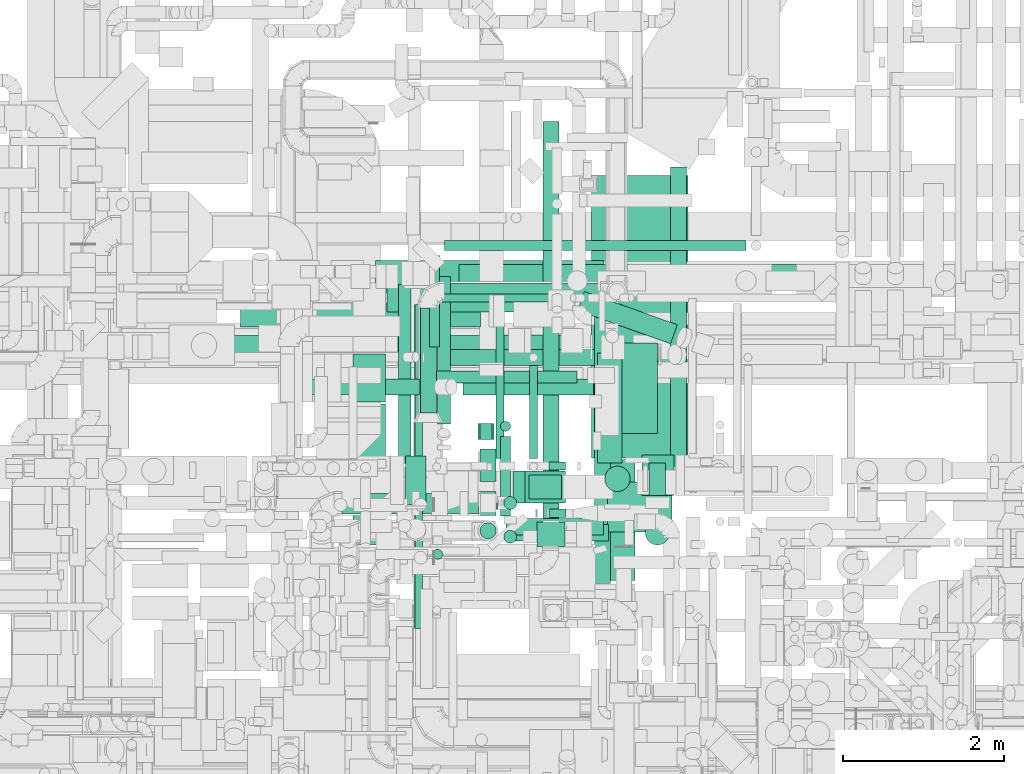
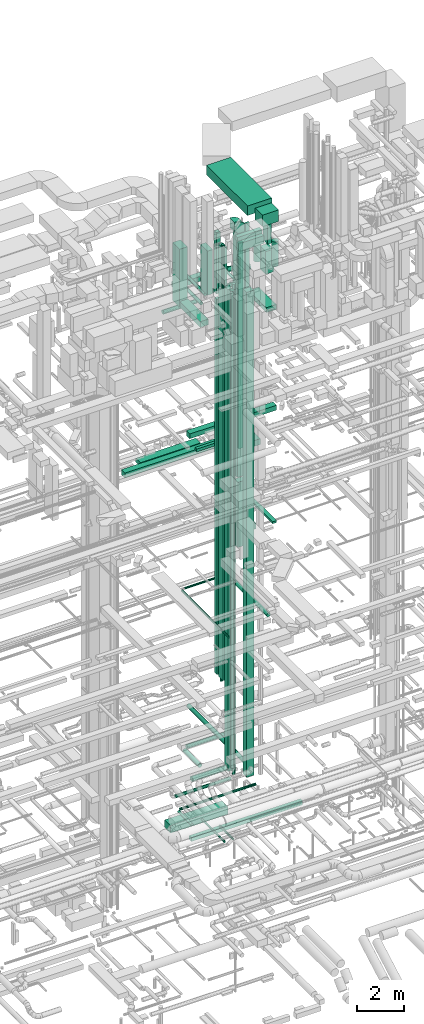
# One storey, part 48 of 337: 54 flow segments, 1 flow fitting.
"""IFC2X3 building model written with IfcOpenShell, lengths in millimetres."""

from ifc_helpers import new_model, entity, si_unit, converted_unit, derived_unit, direction, frame, frame_2d, origin, origin_2d_with_axis, place, context, subcontext, project, spatial, polyline, circle_curve, parameter, trimmed, segment, composite_curve, rectangle, circle, outline, extrude, source, transform, mapped, material, type_object, type_shapes, element, save


model = new_model("IFC2X3")

# Units and contexts
model_context = context("Model", 3, precision=0.01, world=origin(), true_north=direction((6.12303176911189e-17, 1.0)))
body_context = subcontext(model_context, "Body", "Model", "MODEL_VIEW")
ifc_project = project(units=[si_unit("LENGTHUNIT", "METRE", prefix="MILLI"), si_unit("AREAUNIT", "SQUARE_METRE"), si_unit("VOLUMEUNIT", "CUBIC_METRE"), converted_unit("PLANEANGLEUNIT", "DEGREE", entity("IfcRatioMeasure", 0.0174532925199433), si_unit("PLANEANGLEUNIT", "RADIAN"), dimensions=[0, 0, 0, 0, 0, 0, 0]), si_unit("MASSUNIT", "GRAM", prefix="KILO"), derived_unit("MASSDENSITYUNIT", [(si_unit("MASSUNIT", "GRAM", prefix="KILO"), 1), (si_unit("LENGTHUNIT", "METRE"), -3)]), derived_unit("MOMENTOFINERTIAUNIT", [(si_unit("LENGTHUNIT", "METRE"), 4)]), si_unit("TIMEUNIT", "SECOND"), si_unit("FREQUENCYUNIT", "HERTZ"), si_unit("THERMODYNAMICTEMPERATUREUNIT", "DEGREE_CELSIUS"), derived_unit("THERMALTRANSMITTANCEUNIT", [(si_unit("MASSUNIT", "GRAM", prefix="KILO"), 1), (si_unit("THERMODYNAMICTEMPERATUREUNIT", "KELVIN"), -1), (si_unit("TIMEUNIT", "SECOND"), -3)]), derived_unit("VOLUMETRICFLOWRATEUNIT", [(si_unit("LENGTHUNIT", "METRE"), 3), (si_unit("TIMEUNIT", "SECOND"), -1)]), derived_unit("MASSFLOWRATEUNIT", [(si_unit("MASSUNIT", "GRAM", prefix="KILO"), 1), (si_unit("TIMEUNIT", "SECOND"), -1)]), derived_unit("ROTATIONALFREQUENCYUNIT", [(si_unit("TIMEUNIT", "SECOND"), -1)]), si_unit("ELECTRICCURRENTUNIT", "AMPERE"), si_unit("ELECTRICVOLTAGEUNIT", "VOLT"), si_unit("POWERUNIT", "WATT"), si_unit("FORCEUNIT", "NEWTON", prefix="KILO"), si_unit("ILLUMINANCEUNIT", "LUX"), si_unit("LUMINOUSFLUXUNIT", "LUMEN"), si_unit("LUMINOUSINTENSITYUNIT", "CANDELA"), derived_unit("USERDEFINED", [(si_unit("MASSUNIT", "GRAM", prefix="KILO"), -1), (si_unit("LENGTHUNIT", "METRE"), -2), (si_unit("TIMEUNIT", "SECOND"), 3), (si_unit("LUMINOUSFLUXUNIT", "LUMEN"), 1)]), derived_unit("LINEARVELOCITYUNIT", [(si_unit("LENGTHUNIT", "METRE"), 1), (si_unit("TIMEUNIT", "SECOND"), -1)]), si_unit("PRESSUREUNIT", "PASCAL"), derived_unit("USERDEFINED", [(si_unit("LENGTHUNIT", "METRE"), -2), (si_unit("MASSUNIT", "GRAM", prefix="KILO"), 1), (si_unit("TIMEUNIT", "SECOND"), -2)]), derived_unit("LINEARFORCEUNIT", [(si_unit("MASSUNIT", "GRAM", prefix="KILO"), 1), (si_unit("LENGTHUNIT", "METRE"), 1), (si_unit("TIMEUNIT", "SECOND"), -2), (si_unit("LENGTHUNIT", "METRE"), -1)]), derived_unit("PLANARFORCEUNIT", [(si_unit("MASSUNIT", "GRAM", prefix="KILO"), 1), (si_unit("LENGTHUNIT", "METRE"), 1), (si_unit("TIMEUNIT", "SECOND"), -2), (si_unit("LENGTHUNIT", "METRE"), -2)])], contexts=[model_context])

# Site, building, storey
site_placement = place(None, origin())
site = spatial("IfcSite", under=ifc_project, at=site_placement, CompositionType="ELEMENT")
building_placement = place(site_placement, origin())
building = spatial("IfcBuilding", under=site, at=building_placement, CompositionType="ELEMENT")
storey_placement = place(building_placement, origin())
storey = spatial("IfcBuildingStorey", under=building, at=storey_placement, CompositionType="ELEMENT", Elevation=0.0)

# Flow segments
duct_segment_type_1 = type_object("IfcDuctSegmentType", PredefinedType="NOTDEFINED")
flow_segment_1_placement = place(storey_placement, frame((50395.13, 15098.96, -1050.0)))
element("IfcFlowSegment", 1, at=flow_segment_1_placement, inside=storey, type_object=duct_segment_type_1, context=body_context, shape_type="SweptSolid", body=[
    extrude(rectangle(XDim=2826.04187500001, YDim=499.999999999999, at=origin_2d_with_axis()), frame((1413.02, 250.0, 0.0), z_axis=(0.0, 0.0, 1.0), x_axis=(-1.0, 0.0, 0.0)), (0.0, 0.0, 1.0), 400.0),
])
flow_segment_2_placement = place(storey_placement, frame((50970.11, 14298.39, -1200.0)))
element("IfcFlowSegment", 2, at=flow_segment_2_placement, inside=storey, type_object=duct_segment_type_1, context=body_context, shape_type="SweptSolid", body=[
    extrude(rectangle(XDim=5476.96362227127, YDim=200.0, at=origin_2d_with_axis()), frame((2738.48, 100.0, 0.0), z_axis=(0.0, 0.0, 1.0), x_axis=(-1.0, 0.0, 0.0)), (0.0, 0.0, 1.0), 200.0),
])
flow_segment_3_placement = place(storey_placement, frame((51689.86, 12435.9, 3324.92)))
element("IfcFlowSegment", 3, at=flow_segment_3_placement, inside=storey, type_object=duct_segment_type_1, context=body_context, shape_type="SweptSolid", body=[
    extrude(rectangle(XDim=299.999999999999, YDim=199.999999999998, at=origin_2d_with_axis()), frame((100.0, 150.42, 0.0), z_axis=(0.0, -1.68415597509153e-05, 1.0), x_axis=(0.0, -1.0, -1.68415597509153e-05)), (0.0, 0.0, 1.0), 25125.0733909104),
])
flow_segment_4_placement = place(storey_placement, frame((47728.66, 14375.32, 18850.0)))
element("IfcFlowSegment", 4, at=flow_segment_4_placement, inside=storey, type_object=duct_segment_type_1, context=body_context, shape_type="SweptSolid", body=[
    extrude(rectangle(XDim=5030.37124732486, YDim=300.000000000001, at=origin_2d_with_axis()), frame((2515.19, 150.0, 0.0)), (0.0, 0.0, 1.0), 249.999999999999),
])
flow_segment_5_placement = place(storey_placement, frame((53390.04, 13456.14, 19000.0)))
element("IfcFlowSegment", 5, at=flow_segment_5_placement, inside=storey, type_object=duct_segment_type_1, context=body_context, shape_type="SweptSolid", body=[
    extrude(rectangle(XDim=1119.37500000002, YDim=499.999999999999, at=origin_2d_with_axis()), frame((250.0, 559.69, 0.0), z_axis=(0.0, 0.0, 1.0), x_axis=(0.0, -1.0, 0.0)), (0.0, 0.0, 1.0), 300.000000000001),
])
flow_segment_6_placement = place(storey_placement, frame((48720.04, 14775.52, 18850.0)))
element("IfcFlowSegment", 6, at=flow_segment_6_placement, inside=storey, type_object=duct_segment_type_1, context=body_context, shape_type="SweptSolid", body=[
    extrude(rectangle(XDim=2976.44660940693, YDim=400.0, at=origin_2d_with_axis()), frame((1488.22, 200.0, 0.0), z_axis=(0.0, 0.0, 1.0), x_axis=(-1.0, 0.0, 0.0)), (0.0, 0.0, 1.0), 199.999999999998),
])
flow_segment_7_placement = place(storey_placement, frame((52300.19, 12641.61, 14665.15)))
element("IfcFlowSegment", 7, at=flow_segment_7_placement, inside=storey, type_object=duct_segment_type_1, context=body_context, shape_type="SweptSolid", body=[
    extrude(rectangle(XDim=300.000000000001, YDim=399.999999999996, at=origin_2d_with_axis()), frame((200.0, 150.0, 0.0), z_axis=(0.0, 0.0, 1.0), x_axis=(0.0, -1.0, 0.0)), (0.0, 0.0, 1.0), 3400.00000000017),
])
flow_segment_8_placement = place(storey_placement, frame((52250.21, 12591.63, 18365.15)))
element("IfcFlowSegment", 8, at=flow_segment_8_placement, inside=storey, type_object=duct_segment_type_1, context=body_context, shape_type="SweptSolid", body=[
    extrude(rectangle(XDim=399.999999999998, YDim=499.999999999999, at=origin_2d_with_axis()), frame((250.0, 200.0, 0.0), z_axis=(0.0, 0.0, 1.0), x_axis=(0.0, -1.0, 0.0)), (0.0, 0.0, 1.0), 12704.845638508),
])
flow_segment_9_placement = place(storey_placement, frame((51433.15, 15251.67, 19059.58)))
element("IfcFlowSegment", 9, at=flow_segment_9_placement, inside=storey, type_object=duct_segment_type_1, context=body_context, shape_type="SweptSolid", body=[
    extrude(rectangle(XDim=4283.92321391486, YDim=299.999999999999, at=origin_2d_with_axis()), frame((2141.96, 150.0, 0.0), z_axis=(0.0, 0.0, 1.0), x_axis=(-1.0, 0.0, 0.0)), (0.0, 0.0, 1.0), 249.999999999999),
])
flow_segment_10_placement = place(storey_placement, frame((51099.92, 14082.73, 19200.0)))
element("IfcFlowSegment", 10, at=flow_segment_10_placement, inside=storey, type_object=duct_segment_type_1, context=body_context, shape_type="SweptSolid", body=[
    extrude(rectangle(XDim=1796.80194846607, YDim=150.000000000001, at=origin_2d_with_axis()), frame((898.4, 75.0, 0.0)), (0.0, 0.0, 1.0), 150.000000000001),
])
flow_segment_11_placement = place(storey_placement, frame((53150.19, 13091.61, 14975.0)))
element("IfcFlowSegment", 11, at=flow_segment_11_placement, inside=storey, type_object=duct_segment_type_1, context=body_context, shape_type="SweptSolid", body=[
    extrude(rectangle(XDim=1360.74113227847, YDim=300.000000000001, at=origin_2d_with_axis()), frame((150.0, 680.37, 0.0), z_axis=(0.0, 0.0, 1.0), x_axis=(0.0, 1.0, 0.0)), (0.0, 0.0, 1.0), 300.000000000001),
])
flow_segment_12_placement = place(storey_placement, frame((54053.97, 12716.31, 15250.0)))
element("IfcFlowSegment", 12, at=flow_segment_12_placement, inside=storey, type_object=duct_segment_type_1, context=body_context, shape_type="SweptSolid", body=[
    extrude(rectangle(XDim=4044.03858388434, YDim=199.999999999998, at=origin_2d_with_axis()), frame((100.0, 2022.02, 0.0), z_axis=(0.0, 0.0, 1.0), x_axis=(0.0, 1.0, 0.0)), (0.0, 0.0, 1.0), 99.9999999999989),
])
flow_segment_13_placement = place(storey_placement, frame((50116.44, 13844.03, 27243.0)))
element("IfcFlowSegment", 13, at=flow_segment_13_placement, inside=storey, type_object=duct_segment_type_1, context=body_context, shape_type="SweptSolid", body=[
    extrude(rectangle(XDim=600.0, YDim=399.999999999996, at=origin_2d_with_axis()), frame((200.0, 300.0, 0.0), z_axis=(0.0, 0.0, 1.0), x_axis=(0.0, -1.0, 0.0)), (0.0, 0.0, 1.0), 3007.00307653758),
])
flow_segment_14_placement = place(storey_placement, frame((50116.44, 12073.64, 27250.0)))
element("IfcFlowSegment", 14, at=flow_segment_14_placement, inside=storey, type_object=duct_segment_type_1, context=body_context, shape_type="SweptSolid", body=[
    extrude(rectangle(XDim=1750.39648480478, YDim=399.999999999996, at=origin_2d_with_axis()), frame((200.0, 875.2, 0.0), z_axis=(0.0, 0.0, 1.0), x_axis=(0.0, 1.0, 0.0)), (0.0, 0.0, 1.0), 300.000000000001),
])
flow_segment_15_placement = place(storey_placement, frame((50536.44, 14962.85, 27325.0)))
element("IfcFlowSegment", 15, at=flow_segment_15_placement, inside=storey, type_object=duct_segment_type_1, context=body_context, shape_type="SweptSolid", body=[
    extrude(rectangle(XDim=1799.99999999999, YDim=299.999999999999, at=origin_2d_with_axis()), frame((900.0, 150.0, 0.0)), (0.0, 0.0, 1.0), 250.000000000004),
])
flow_segment_16_placement = place(storey_placement, frame((53115.82, 11630.54, 27250.0)))
element("IfcFlowSegment", 16, at=flow_segment_16_placement, inside=storey, type_object=duct_segment_type_1, context=body_context, shape_type="SweptSolid", body=[
    extrude(rectangle(XDim=1502.49550800527, YDim=499.999999999999, at=origin_2d_with_axis()), frame((250.0, 751.25, 0.0), z_axis=(0.0, 0.0, 1.0), x_axis=(0.0, -1.0, 0.0)), (0.0, 0.0, 1.0), 250.000000000004),
])
flow_segment_17_placement = place(storey_placement, frame((51691.52, 13382.59, 7800.0)))
element("IfcFlowSegment", 17, at=flow_segment_17_placement, inside=storey, type_object=duct_segment_type_1, context=body_context, shape_type="SweptSolid", body=[
    extrude(rectangle(XDim=200.000000000002, YDim=150.000000000001, at=origin_2d_with_axis()), frame((75.0, 100.0, 0.0), z_axis=(0.0, 0.0, 1.0), x_axis=(0.0, 1.0, 0.0)), (0.0, 0.0, 1.0), 19560.000025),
])
flow_segment_18_placement = place(storey_placement, frame((50768.68, 12574.75, 28400.0)))
element("IfcFlowSegment", 18, at=flow_segment_18_placement, inside=storey, type_object=duct_segment_type_1, context=body_context, shape_type="SweptSolid", body=[
    extrude(rectangle(XDim=249.999999999995, YDim=600.0, at=origin_2d_with_axis()), frame((125.0, 300.0, 0.0)), (0.0, 0.0, 1.0), 2300.0),
])
flow_segment_19_placement = place(storey_placement, frame((52549.74, 13003.66, 19500.0)))
element("IfcFlowSegment", 19, at=flow_segment_19_placement, inside=storey, type_object=duct_segment_type_1, context=body_context, shape_type="SweptSolid", body=[
    extrude(rectangle(XDim=200.000000000007, YDim=100.000000000001, at=origin_2d_with_axis()), frame((100.0, 50.0, 0.0)), (0.0, 0.0, 1.0), 10740.0),
])
flow_segment_20_placement = place(storey_placement, frame((51666.52, 13382.59, 27660.0)))
element("IfcFlowSegment", 20, at=flow_segment_20_placement, inside=storey, type_object=duct_segment_type_1, context=body_context, shape_type="SweptSolid", body=[
    extrude(rectangle(XDim=199.999999999998, YDim=199.999999999998, at=origin_2d_with_axis()), frame((100.0, 100.0, 0.0), z_axis=(0.0, 0.0, 1.0), x_axis=(0.0, 1.0, 0.0)), (0.0, 0.0, 1.0), 3190.00000000022),
])
flow_segment_21_placement = place(storey_placement, frame((52041.36, 12124.0, 30500.0)))
element("IfcFlowSegment", 21, at=flow_segment_21_placement, inside=storey, type_object=duct_segment_type_1, context=body_context, shape_type="SweptSolid", body=[
    extrude(rectangle(XDim=1242.93967972334, YDim=200.0, at=origin_2d_with_axis()), frame((621.47, 100.0, 0.0)), (0.0, 0.0, 1.0), 400.000000000004),
])
flow_segment_22_placement = place(storey_placement, frame((53700.03, 12689.46, 28400.23)))
element("IfcFlowSegment", 22, at=flow_segment_22_placement, inside=storey, type_object=duct_segment_type_1, context=body_context, shape_type="SweptSolid", body=[
    extrude(rectangle(XDim=399.999999999996, YDim=500.000000000001, at=origin_2d_with_axis()), frame((200.0, 250.0, 0.0), z_axis=(0.0, 0.0, 1.0), x_axis=(-1.0, 0.0, 0.0)), (0.0, 0.0, 1.0), 1180.0),
])
flow_segment_23_placement = place(storey_placement, frame((53790.28, 12689.46, 29925.0)))
element("IfcFlowSegment", 23, at=flow_segment_23_placement, inside=storey, type_object=duct_segment_type_1, context=body_context, shape_type="SweptSolid", body=[
    extrude(rectangle(XDim=200.000000000007, YDim=400.0, at=origin_2d_with_axis()), frame((100.0, 200.0, 0.0), z_axis=(0.0, 0.0, 1.0), x_axis=(-1.0, 0.0, 0.0)), (0.0, 0.0, 1.0), 1320.0),
])
flow_segment_24_placement = place(storey_placement, frame((52396.74, 12056.96, 3000.0)))
element("IfcFlowSegment", 24, at=flow_segment_24_placement, inside=storey, type_object=duct_segment_type_1, context=body_context, shape_type="SweptSolid", body=[
    extrude(rectangle(XDim=300.000000000003, YDim=349.999999999998, at=origin_2d_with_axis()), frame((175.0, 150.0, 0.0), z_axis=(0.0, 0.0, 1.0), x_axis=(0.0, -1.0, 0.0)), (0.0, 0.0, 1.0), 25292.5),
])
flow_segment_25_placement = place(storey_placement, frame((52550.22, 12416.31, 15370.0)))
element("IfcFlowSegment", 25, at=flow_segment_25_placement, inside=storey, type_object=duct_segment_type_1, context=body_context, shape_type="SweptSolid", body=[
    extrude(rectangle(XDim=99.9999999999989, YDim=199.999999999998, at=origin_2d_with_axis()), frame((100.0, 50.0, 0.0), z_axis=(0.0, 0.0, 1.0), x_axis=(0.0, 1.0, 0.0)), (0.0, 0.0, 1.0), 16230.0),
])
flow_segment_26_placement = place(storey_placement, frame((52016.52, 12199.6, 31000.0)))
element("IfcFlowSegment", 26, at=flow_segment_26_placement, inside=storey, type_object=duct_segment_type_1, context=body_context, shape_type="SweptSolid", body=[
    extrude(rectangle(XDim=1208.51321000022, YDim=200.0, at=origin_2d_with_axis()), frame((604.26, 100.0, 0.0)), (0.0, 0.0, 1.0), 199.999999999998),
])
flow_segment_27_placement = place(storey_placement, frame((51691.36, 12861.01, 7807.5)))
element("IfcFlowSegment", 27, at=flow_segment_27_placement, inside=storey, type_object=duct_segment_type_1, context=body_context, shape_type="SweptSolid", body=[
    extrude(rectangle(XDim=200.000000000007, YDim=400.0, at=origin_2d_with_axis()), frame((100.0, 200.0, 0.0)), (0.0, 0.0, 1.0), 22542.5000250004),
])
flow_segment_28_placement = place(storey_placement, frame((53271.11, 12235.34, 31300.0)))
element("IfcFlowSegment", 28, at=flow_segment_28_placement, inside=storey, type_object=duct_segment_type_1, context=body_context, shape_type="SweptSolid", body=[
    extrude(rectangle(XDim=617.232384388289, YDim=800.0, at=origin_2d_with_axis()), frame((400.0, 308.62, 0.0), z_axis=(0.0, 0.0, 1.0), x_axis=(0.0, 1.0, 0.0)), (0.0, 0.0, 1.0), 600.000000000002),
])
flow_segment_29_placement = place(storey_placement, frame((53071.11, 13152.58, 31400.0)))
element("IfcFlowSegment", 29, at=flow_segment_29_placement, inside=storey, type_object=duct_segment_type_1, context=body_context, shape_type="SweptSolid", body=[
    extrude(rectangle(XDim=3506.16728670528, YDim=1200.0, at=origin_2d_with_axis()), frame((600.0, 1753.08, 0.0), z_axis=(0.0, 0.0, 1.0), x_axis=(0.0, -1.0, 0.0)), (0.0, 0.0, 1.0), 499.999999999999),
])
duct_segment_type_2 = type_object("IfcDuctSegmentType", PredefinedType="NOTDEFINED")
flow_segment_30_placement = place(storey_placement, frame((51887.5, 13143.4, -901.6)))
element("IfcFlowSegment", 30, at=flow_segment_30_placement, inside=storey, type_object=duct_segment_type_2, context=body_context, shape_type="SweptSolid", body=[
    extrude(circle(Radius=50.0, at=origin_2d_with_axis()), frame((51.6, 0.0, 51.6), z_axis=(0.0, 1.0, 0.0), x_axis=(1.0, 0.0, 0.0)), (0.0, 0.0, 1.0), 1935.5532200004),
])
flow_segment_31_placement = place(storey_placement, frame((51062.27, 14527.31, -574.1)))
element("IfcFlowSegment", 31, at=flow_segment_31_placement, inside=storey, type_object=duct_segment_type_2, context=body_context, shape_type="SweptSolid", body=[
    extrude(circle(Radius=62.5, at=origin_2d_with_axis()), frame((64.1, 0.0, 64.1), z_axis=(0.0, 1.0, 0.0), x_axis=(1.0, 0.0, 0.0)), (0.0, 0.0, 1.0), 1134.40804999999),
])
flow_segment_32_placement = place(storey_placement, frame((51251.36, 15722.62, -574.1)))
element("IfcFlowSegment", 32, at=flow_segment_32_placement, inside=storey, type_object=duct_segment_type_2, context=body_context, shape_type="SweptSolid", body=[
    extrude(circle(Radius=62.5, at=origin_2d_with_axis()), frame((0.0, 64.1, 64.1), z_axis=(1.0, 0.0, 0.0), x_axis=(0.0, -1.0, 0.0)), (0.0, 0.0, 1.0), 3740.22692000001),
])
flow_segment_33_placement = place(storey_placement, frame((52303.03, 13143.39, -901.6)))
element("IfcFlowSegment", 33, at=flow_segment_33_placement, inside=storey, type_object=duct_segment_type_2, context=body_context, shape_type="SweptSolid", body=[
    extrude(circle(Radius=50.0, at=origin_2d_with_axis()), frame((51.6, 0.0, 51.6), z_axis=(0.0, 1.0, 0.0), x_axis=(1.0, 0.0, 0.0)), (0.0, 0.0, 1.0), 1155.00103000007),
])
flow_segment_34_placement = place(storey_placement, frame((50878.54, 11037.97, 11398.4)))
element("IfcFlowSegment", 34, at=flow_segment_34_placement, inside=storey, type_object=duct_segment_type_2, context=body_context, shape_type="SweptSolid", body=[
    extrude(circle(Radius=50.0, at=origin_2d_with_axis()), frame((51.6, 0.0, 51.6), z_axis=(0.0, 1.0, 0.0), x_axis=(-1.0, 0.0, 0.0)), (0.0, 0.0, 1.0), 4017.81417840207),
])
flow_segment_35_placement = place(storey_placement, frame((53108.29, 11595.4, 11368.4)))
element("IfcFlowSegment", 35, at=flow_segment_35_placement, inside=storey, type_object=duct_segment_type_2, context=body_context, shape_type="SweptSolid", body=[
    extrude(circle(Radius=100.0, at=origin_2d_with_axis()), frame((101.6, 0.0, 101.6), z_axis=(0.0, 1.0, 0.0), x_axis=(-1.0, 0.0, 0.0)), (0.0, 0.0, 1.0), 3639.44716947903),
])
flow_segment_36_placement = place(storey_placement, frame((51120.61, 15086.69, 11398.4)))
element("IfcFlowSegment", 36, at=flow_segment_36_placement, inside=storey, type_object=duct_segment_type_2, context=body_context, shape_type="SweptSolid", body=[
    extrude(circle(Radius=50.0, at=origin_2d_with_axis()), frame((0.0, 51.6, 51.6), z_axis=(1.0, 0.0, 0.0), x_axis=(0.0, -1.0, 0.0)), (0.0, 0.0, 1.0), 1654.29864376274),
])
flow_segment_37_placement = place(storey_placement, frame((51690.12, 12147.45, 3650.0)))
element("IfcFlowSegment", 37, at=flow_segment_37_placement, inside=storey, type_object=duct_segment_type_2, context=body_context, shape_type="SweptSolid", body=[
    extrude(circle(Radius=100.0, at=origin_2d_with_axis()), frame((101.6, 101.6, 0.0), z_axis=(0.0, 0.0, 1.0), x_axis=(0.0, 1.0, 0.0)), (0.0, 0.0, 1.0), 24854.3307107923),
])
flow_segment_38_placement = place(storey_placement, frame((52900.27, 14567.38, 27323.4)))
element("IfcFlowSegment", 38, at=flow_segment_38_placement, inside=storey, type_object=duct_segment_type_2, context=body_context, shape_type="SweptSolid", body=[
    extrude(circle(Radius=125.0, at=origin_2d_with_axis()), frame((43.65, 530.9, 126.6), z_axis=(0.941697054037873, -0.336461971723986, 0.0), x_axis=(0.336461971723986, 0.941697054037873, 0.0)), (0.0, 0.0, 1.0), 1223.28442181313),
])
flow_segment_39_placement = place(storey_placement, frame((51478.66, 13932.68, 27273.4)))
element("IfcFlowSegment", 39, at=flow_segment_39_placement, inside=storey, type_object=duct_segment_type_2, context=body_context, shape_type="SweptSolid", body=[
    extrude(circle(Radius=100.0, at=origin_2d_with_axis()), frame((0.0, 101.6, 101.6), z_axis=(1.0, 0.0, 0.0), x_axis=(0.0, 1.0, 0.0)), (0.0, 0.0, 1.0), 1617.15728752538),
])
flow_segment_40_placement = place(storey_placement, frame((49395.82, 13932.68, 27013.11)))
element("IfcFlowSegment", 40, at=flow_segment_40_placement, inside=storey, type_object=duct_segment_type_2, context=body_context, shape_type="SweptSolid", body=[
    extrude(circle(Radius=100.0, at=origin_2d_with_axis()), frame((0.0, 101.6, 101.6), z_axis=(1.0, 0.0, 0.0), x_axis=(0.0, 1.0, 0.0)), (0.0, 0.0, 1.0), 1656.8641401057),
])
flow_segment_41_placement = place(storey_placement, frame((51942.31, 13481.25, 7275.0)))
element("IfcFlowSegment", 41, at=flow_segment_41_placement, inside=storey, type_object=duct_segment_type_2, context=body_context, shape_type="SweptSolid", body=[
    extrude(outline(polyline([(-8.16, -61.97), (8.16, -61.97), (23.92, -57.74), (38.05, -49.58), (49.58, -38.05), (57.74, -23.92), (61.97, -8.16), (61.97, 8.16), (57.74, 23.92), (49.58, 38.05), (38.05, 49.58), (23.92, 57.74), (8.16, 61.97), (-8.16, 61.97), (-23.92, 57.74), (-38.05, 49.58), (-49.58, 38.05), (-57.74, 23.92), (-61.97, 8.16), (-61.97, -8.16), (-57.74, -23.92), (-49.58, -38.05), (-38.05, -49.58), (-23.92, -57.74), (-8.16, -61.97)])), frame((64.1, 64.1, 0.0), z_axis=(-4.73471211458744e-08, 0.0, 1.0), x_axis=(0.130526192220062, -0.991444861373809, 6.19471494744495e-09)), (0.0, 0.0, 1.0), 21500.0000000001),
])
flow_segment_42_placement = place(storey_placement, frame((50675.03, 13080.58, 27588.4)))
element("IfcFlowSegment", 42, at=flow_segment_42_placement, inside=storey, type_object=duct_segment_type_2, context=body_context, shape_type="SweptSolid", body=[
    extrude(circle(Radius=80.0, at=origin_2d_with_axis()), frame((81.6, 0.0, 81.6), z_axis=(0.0, 1.0, 0.0), x_axis=(1.0, 0.0, 0.0)), (0.0, 0.0, 1.0), 2221.25000000001),
])
flow_segment_43_placement = place(storey_placement, frame((51161.31, 13575.4, 27598.4)))
element("IfcFlowSegment", 43, at=flow_segment_43_placement, inside=storey, type_object=duct_segment_type_2, context=body_context, shape_type="SweptSolid", body=[
    extrude(circle(Radius=80.0, at=origin_2d_with_axis()), frame((81.6, 0.0, 81.6), z_axis=(0.0, 1.0, 0.0), x_axis=(-1.0, 0.0, 0.0)), (0.0, 0.0, 1.0), 1830.73181316514),
])
flow_segment_44_placement = place(storey_placement, frame((53740.94, 12072.4, 29107.5)))
element("IfcFlowSegment", 44, at=flow_segment_44_placement, inside=storey, type_object=duct_segment_type_2, context=body_context, shape_type="SweptSolid", body=[
    extrude(circle(Radius=150.0, at=origin_2d_with_axis()), frame((151.6, 151.6, 0.0), z_axis=(0.0, 0.0, 1.0), x_axis=(0.0, -1.0, 0.0)), (0.0, 0.0, 1.0), 1292.50002499996),
])
flow_segment_45_placement = place(storey_placement, frame((53236.57, 12734.42, 29122.5)))
element("IfcFlowSegment", 45, at=flow_segment_45_placement, inside=storey, type_object=duct_segment_type_2, context=body_context, shape_type="SweptSolid", body=[
    extrude(circle(Radius=157.5, at=origin_2d_with_axis()), frame((159.1, 159.1, 0.0), z_axis=(0.0, 0.0, 1.0), x_axis=(0.0, 1.0, 0.0)), (0.0, 0.0, 1.0), 1052.05054606743),
])
flow_segment_46_placement = place(storey_placement, frame((51984.77, 12092.4, 28865.0)))
element("IfcFlowSegment", 46, at=flow_segment_46_placement, inside=storey, type_object=duct_segment_type_2, context=body_context, shape_type="SweptSolid", body=[
    extrude(circle(Radius=80.0, at=origin_2d_with_axis()), frame((81.6, 81.6, 0.0), z_axis=(0.0, 0.0, 1.0), x_axis=(0.0, -1.0, 0.0)), (0.0, 0.0, 1.0), 1280.00000000002),
])
flow_segment_47_placement = place(storey_placement, frame((51941.96, 12434.17, 28835.9)))
element("IfcFlowSegment", 47, at=flow_segment_47_placement, inside=storey, type_object=duct_segment_type_2, context=body_context, shape_type="SweptSolid", body=[
    extrude(circle(Radius=62.5, at=origin_2d_with_axis()), frame((64.1, 0.02, 64.1), z_axis=(0.000311458642591217, 0.999999951496756, 0.0), x_axis=(0.999999951496756, -0.000311458642591217, 0.0)), (0.0, 0.0, 1.0), 986.162382223569),
])
flow_segment_48_placement = place(storey_placement, frame((51101.92, 11892.73, 29025.0)))
element("IfcFlowSegment", 48, at=flow_segment_48_placement, inside=storey, type_object=duct_segment_type_2, context=body_context, shape_type="SweptSolid", body=[
    extrude(circle(Radius=62.5, at=origin_2d_with_axis()), frame((64.1, 64.1, 0.0), z_axis=(0.0, 0.0, 1.0), x_axis=(-1.0, 0.0, 0.0)), (0.0, 0.0, 1.0), 2260.00000000001),
])
flow_segment_49_placement = place(storey_placement, frame((52470.14, 12376.96, 3398.4)))
element("IfcFlowSegment", 49, at=flow_segment_49_placement, inside=storey, type_object=duct_segment_type_2, context=body_context, shape_type="SweptSolid", body=[
    extrude(circle(Radius=100.0, at=origin_2d_with_axis()), frame((101.6, 0.0, 101.6), z_axis=(0.0, 1.0, 0.0), x_axis=(1.0, 0.0, 0.0)), (0.0, 0.0, 1.0), 4949.99999999996),
])
flow_segment_50_placement = place(storey_placement, frame((49163.34, 12512.32, 2738.4)))
element("IfcFlowSegment", 50, at=flow_segment_50_placement, inside=storey, type_object=duct_segment_type_2, context=body_context, shape_type="SweptSolid", body=[
    extrude(circle(Radius=80.0, at=origin_2d_with_axis()), frame((0.0, 81.6, 81.6), z_axis=(1.0, 0.0, 0.0), x_axis=(0.0, 1.0, 0.0)), (0.0, 0.0, 1.0), 2743.11343220573),
])
flow_segment_51_placement = place(storey_placement, frame((51984.77, 12512.32, 2980.0)))
element("IfcFlowSegment", 51, at=flow_segment_51_placement, inside=storey, type_object=duct_segment_type_2, context=body_context, shape_type="SweptSolid", body=[
    extrude(circle(Radius=80.0, at=origin_2d_with_axis()), frame((81.67, 81.6, 0.0), z_axis=(-3.11546372661323e-06, 0.0, 1.0), x_axis=(0.0, -1.0, 0.0)), (0.0, 0.0, 1.0), 25564.9994985113),
])
flow_segment_52_placement = place(storey_placement, frame((49977.54, 12459.16, 3323.4)))
element("IfcFlowSegment", 52, at=flow_segment_52_placement, inside=storey, type_object=duct_segment_type_2, context=body_context, shape_type="SweptSolid", body=[
    extrude(circle(Radius=125.0, at=origin_2d_with_axis()), frame((0.0, 126.6, 126.6), z_axis=(1.0, 0.0, 0.0), x_axis=(0.0, 1.0, 0.0)), (0.0, 0.0, 1.0), 1692.31889087023),
])
duct_segment_type_3 = type_object("IfcDuctSegmentType", PredefinedType="NOTDEFINED")
flow_segment_53_placement = place(storey_placement, frame((50946.67, 13710.07, 2998.38)))
element("IfcFlowSegment", 53, at=flow_segment_53_placement, inside=storey, type_object=duct_segment_type_3, context=body_context, shape_type="SweptSolid", body=[
    extrude(circle(Radius=100.0, at=origin_2d_with_axis()), frame((101.6, 0.0, 101.6), z_axis=(0.0, 1.0, 0.0), x_axis=(1.0, 0.0, 0.0)), (0.0, 0.0, 1.0), 1305.00000973617),
])
flow_segment_54_placement = place(storey_placement, frame((51248.26, 15113.48, 2998.38)))
element("IfcFlowSegment", 54, at=flow_segment_54_placement, inside=storey, type_object=duct_segment_type_3, context=body_context, shape_type="SweptSolid", body=[
    extrude(circle(Radius=100.0, at=origin_2d_with_axis()), frame((0.0, 101.6, 101.6), z_axis=(1.0, 0.0, 0.0), x_axis=(0.0, 1.0, 0.0)), (0.0, 0.0, 1.0), 1940.00089243215),
])

# Flow fitting
ifc_material = material()
duct_fitting_type = type_object("IfcDuctFittingType", PredefinedType="NOTDEFINED", material=ifc_material)
shared_shape = source(origin(), body_context, "Body", "SweptSolid", [
    extrude(outline(composite_curve([segment(polyline([(-450.0, -200.0), (50.0, -200.0)]), True, "CONTINUOUS"), segment(trimmed(circle_curve(frame_2d((200.0, -200.0), x_axis=(0.0, 1.0)), 150.0), [parameter(0.0)], [parameter(90.0000000000001)], True, "PARAMETER"), False, "CONTINUOUS"), segment(polyline([(200.0, -50.0), (200.0, 450.0)]), True, "CONTINUOUS"), segment(trimmed(circle_curve(frame_2d((200.0, -200.0), x_axis=(0.0, 1.0)), 650.0), [parameter(0.0)], [parameter(90.0000000000001)], True, "PARAMETER"), True, "CONTINUOUS")], self_intersect=False)), frame((-200.0, 200.0, -200.0), z_axis=(0.0, 0.0, 1.0), x_axis=(-1.0, 0.0, 0.0)), (0.0, 0.0, 1.0), 400.0),
])
type_shapes(duct_fitting_type, [shared_shape])
flow_fitting_placement = place(storey_placement, frame((52500.21, 12791.6, 31470.0), z_axis=(0.0, 1.0, 5.98418663201702e-05), x_axis=(1.0, 0.0, 0.0)))
element("IfcFlowFitting", 55, at=flow_fitting_placement, inside=storey, type_object=duct_fitting_type, material=ifc_material, context=body_context, shape_type="MappedRepresentation", body=[
    mapped(shared_shape, transform((0.0, 0.0, 0.0), scale=1.0)),
])

save(model, "model.ifc")
